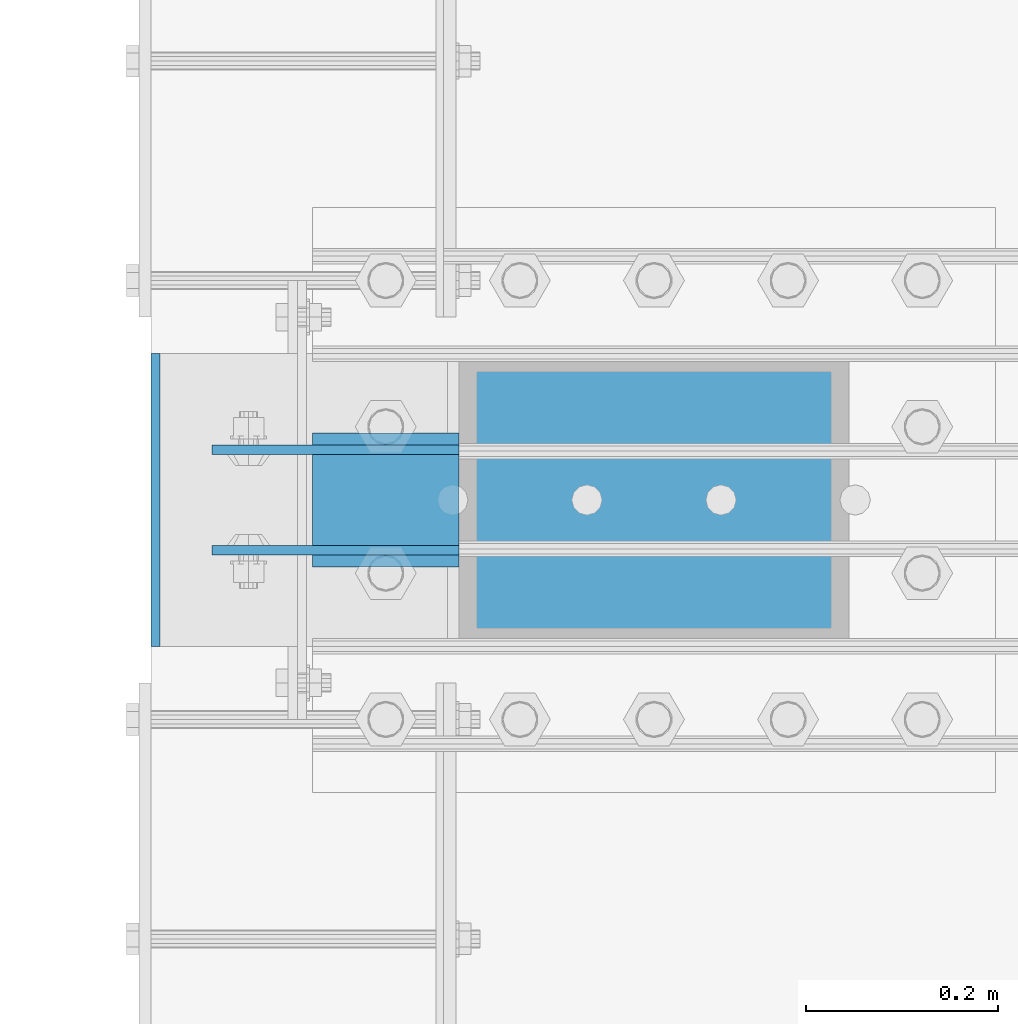
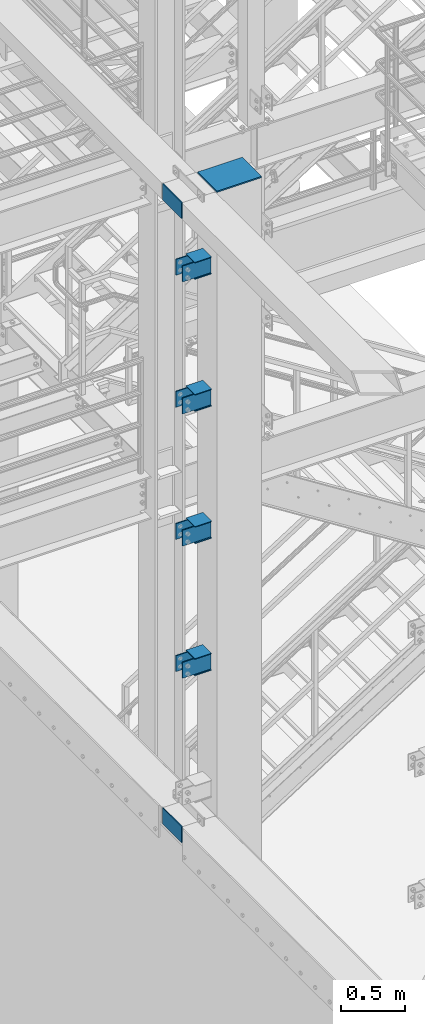
# One storey, part 1105 of 1876: 19 beams, 1 element without a shape of its own.
"""IFC2X3 building model written with IfcOpenShell, lengths in millimetres."""

from ifc_helpers import new_model, si_unit, frame, origin_with_axes, place, context, subcontext, project, spatial, faceted_brep, material, type_object, element, aggregate, save


model = new_model("IFC2X3")

# Units and contexts
model_context = context("Model", 3, precision=1e-05, world=origin_with_axes())
body_context = subcontext(model_context, "Body", "Model", "MODEL_VIEW")
ifc_project = project(units=[si_unit("LENGTHUNIT", "METRE", prefix="MILLI"), si_unit("AREAUNIT", "SQUARE_METRE"), si_unit("VOLUMEUNIT", "CUBIC_METRE"), si_unit("MASSUNIT", "GRAM", prefix="KILO"), si_unit("TIMEUNIT", "SECOND"), si_unit("PLANEANGLEUNIT", "RADIAN"), si_unit("SOLIDANGLEUNIT", "STERADIAN"), si_unit("THERMODYNAMICTEMPERATUREUNIT", "DEGREE_CELSIUS"), si_unit("LUMINOUSINTENSITYUNIT", "LUMEN")], contexts=[model_context])

# Site, building, storey
site_placement = place(None, origin_with_axes())
site = spatial("IfcSite", under=ifc_project, at=site_placement, CompositionType="ELEMENT")
building_placement = place(site_placement, origin_with_axes())
building = spatial("IfcBuilding", under=site, at=building_placement, Name="Undefined", CompositionType="ELEMENT")
storey_placement = place(building_placement, origin_with_axes())
storey = spatial("IfcBuildingStorey", under=building, at=storey_placement, Name="Undefined", CompositionType="ELEMENT", Elevation=0.0)

# Assembly, beams
assembly_placement = place(storey_placement, origin_with_axes())
assembly = element("IfcElementAssembly", 1, at=assembly_placement, inside=storey, Name="COLUMN", AssemblyPlace="NOTDEFINED", PredefinedType="RIGID_FRAME")
ifc_material = material(Name="STEEL/A36")
beam_type_1 = type_object("IfcBeamType", PredefinedType="NOTDEFINED")
beam_1_placement = place(assembly_placement, frame((434.975, -10769.6, 10661.65), z_axis=(0.0, 1.0, 0.0), x_axis=(-1.0, 0.0, 0.0)))
beam_1 = element("IfcBeam", 2, at=beam_1_placement, type_object=beam_type_1, material=ifc_material, Name="PLATE", context=body_context, shape_type="Brep", body=[
    faceted_brep([(0.0, 6.35000000000002, -152.4), (0.0, 6.35000000000002, 152.4), (406.4, 6.35000000000036, 152.4), (406.4, 6.35000000000036, -152.4), (0.0, -6.35000000000002, 152.4), (406.4, -6.35000000000036, 152.4), (0.0, -6.35000000000002, -152.4), (406.4, -6.35000000000036, -152.4)], [[[0, 1, 2, 3]], [[1, 4, 5, 2]], [[4, 6, 7, 5]], [[6, 0, 3, 7]], [[5, 7, 3, 2]], [[6, 4, 1, 0]]]),
])
beam_type_2 = type_object("IfcBeamType", PredefinedType="NOTDEFINED")
beam_2_placement = place(assembly_placement, frame((28.5750000000014, -10717.2125, 9904.4125), z_axis=(0.0, 0.0, -1.0), x_axis=(-1.0, 0.0, 0.0)))
beam_2 = element("IfcBeam", 3, at=beam_2_placement, type_object=beam_type_2, material=ifc_material, Name="PLATE", context=body_context, shape_type="Brep", body=[
    faceted_brep([(0.0, 4.76249999999982, -76.1999999999998), (3.63797880709171e-12, 4.76249999999982, 76.1999969482422), (257.174999999999, 4.76249999999982, 76.1999999999998), (257.174999999999, 4.76249999999982, -76.1999999999998), (3.63797880709171e-12, -4.76249999999982, 76.1999969482422), (257.174999999999, -4.76249999999982, 76.1999999999998), (0.0, -4.76249999999982, -76.1999999999998), (257.174999999999, -4.76249999999982, -76.1999999999998)], [[[0, 1, 2, 3]], [[1, 4, 5, 2]], [[4, 6, 7, 5]], [[6, 0, 3, 7]], [[5, 7, 3, 2]], [[6, 4, 1, 0]]]),
])
beam_3_placement = place(assembly_placement, frame((28.5750000000013, -10717.2125, 8635.47083333333), z_axis=(0.0, 0.0, -1.0), x_axis=(-1.0, 0.0, 0.0)))
beam_3 = element("IfcBeam", 4, at=beam_3_placement, type_object=beam_type_2, material=ifc_material, Name="PLATE", context=body_context, shape_type="Brep", body=[
    faceted_brep([(0.0, 4.76249999999982, -76.1999999999998), (3.63797880709171e-12, 4.76249999999982, 76.1999969482422), (257.174999999999, 4.76249999999982, 76.1999999999998), (257.174999999999, 4.76249999999982, -76.1999999999998), (3.63797880709171e-12, -4.76249999999982, 76.1999969482422), (257.174999999999, -4.76249999999982, 76.1999999999998), (0.0, -4.76249999999982, -76.1999999999998), (257.174999999999, -4.76249999999982, -76.1999999999998)], [[[0, 1, 2, 3]], [[1, 4, 5, 2]], [[4, 6, 7, 5]], [[6, 0, 3, 7]], [[5, 7, 3, 2]], [[6, 4, 1, 0]]]),
])
beam_4_placement = place(assembly_placement, frame((28.5750000000013, -10717.2125, 7366.46302033333), z_axis=(0.0, 0.0, -1.0), x_axis=(-1.0, 0.0, 0.0)))
beam_4 = element("IfcBeam", 5, at=beam_4_placement, type_object=beam_type_2, material=ifc_material, Name="PLATE", context=body_context, shape_type="Brep", body=[
    faceted_brep([(0.0, 4.76249999999982, -76.1999999999998), (3.63797880709171e-12, 4.76249999999982, 76.1999969482422), (257.174999999999, 4.76249999999982, 76.1999999999998), (257.174999999999, 4.76249999999982, -76.1999999999998), (3.63797880709171e-12, -4.76249999999982, 76.1999969482422), (257.174999999999, -4.76249999999982, 76.1999999999998), (0.0, -4.76249999999982, -76.1999999999998), (257.174999999999, -4.76249999999982, -76.1999999999998)], [[[0, 1, 2, 3]], [[1, 4, 5, 2]], [[4, 6, 7, 5]], [[6, 0, 3, 7]], [[5, 7, 3, 2]], [[6, 4, 1, 0]]]),
])
beam_5_placement = place(assembly_placement, frame((28.5750000000013, -10717.2125, 6097.5875), z_axis=(0.0, 0.0, -1.0), x_axis=(-1.0, 0.0, 0.0)))
beam_5 = element("IfcBeam", 6, at=beam_5_placement, type_object=beam_type_2, material=ifc_material, Name="PLATE", context=body_context, shape_type="Brep", body=[
    faceted_brep([(0.0, 4.76249999999982, -76.1999999999998), (3.63797880709171e-12, 4.76249999999982, 76.1999969482422), (257.174999999999, 4.76249999999982, 76.1999999999998), (257.174999999999, 4.76249999999982, -76.1999999999998), (3.63797880709171e-12, -4.76249999999982, 76.1999969482422), (257.174999999999, -4.76249999999982, 76.1999999999998), (0.0, -4.76249999999982, -76.1999999999998), (257.174999999999, -4.76249999999982, -76.1999999999998)], [[[0, 1, 2, 3]], [[1, 4, 5, 2]], [[4, 6, 7, 5]], [[6, 0, 3, 7]], [[5, 7, 3, 2]], [[6, 4, 1, 0]]]),
])
beam_6_placement = place(assembly_placement, frame((28.5750000000013, -10821.9875, 9904.4125), z_axis=(0.0, 0.0, -1.0), x_axis=(-1.0, 0.0, 0.0)))
beam_6 = element("IfcBeam", 7, at=beam_6_placement, type_object=beam_type_2, material=ifc_material, Name="PLATE", context=body_context, shape_type="Brep", body=[
    faceted_brep([(0.0, 4.76249999999982, -76.1999999999998), (3.63797880709171e-12, 4.76249999999982, 76.1999969482422), (257.174999999999, 4.76249999999982, 76.1999999999998), (257.174999999999, 4.76249999999982, -76.1999999999998), (3.63797880709171e-12, -4.76249999999982, 76.1999969482422), (257.174999999999, -4.76249999999982, 76.1999999999998), (0.0, -4.76249999999982, -76.1999999999998), (257.174999999999, -4.76249999999982, -76.1999999999998)], [[[0, 1, 2, 3]], [[1, 4, 5, 2]], [[4, 6, 7, 5]], [[6, 0, 3, 7]], [[5, 7, 3, 2]], [[6, 4, 1, 0]]]),
])
beam_7_placement = place(assembly_placement, frame((28.5750000000013, -10821.9875, 8635.47083333333), z_axis=(0.0, 0.0, -1.0), x_axis=(-1.0, 0.0, 0.0)))
beam_7 = element("IfcBeam", 8, at=beam_7_placement, type_object=beam_type_2, material=ifc_material, Name="PLATE", context=body_context, shape_type="Brep", body=[
    faceted_brep([(0.0, 4.76249999999982, -76.1999999999998), (3.63797880709171e-12, 4.76249999999982, 76.1999969482422), (257.174999999999, 4.76249999999982, 76.1999999999998), (257.174999999999, 4.76249999999982, -76.1999999999998), (3.63797880709171e-12, -4.76249999999982, 76.1999969482422), (257.174999999999, -4.76249999999982, 76.1999999999998), (0.0, -4.76249999999982, -76.1999999999998), (257.174999999999, -4.76249999999982, -76.1999999999998)], [[[0, 1, 2, 3]], [[1, 4, 5, 2]], [[4, 6, 7, 5]], [[6, 0, 3, 7]], [[5, 7, 3, 2]], [[6, 4, 1, 0]]]),
])
beam_8_placement = place(assembly_placement, frame((28.5750000000013, -10821.9875, 7366.46302033333), z_axis=(0.0, 0.0, -1.0), x_axis=(-1.0, 0.0, 0.0)))
beam_8 = element("IfcBeam", 9, at=beam_8_placement, type_object=beam_type_2, material=ifc_material, Name="PLATE", context=body_context, shape_type="Brep", body=[
    faceted_brep([(0.0, 4.76249999999982, -76.1999999999998), (3.63797880709171e-12, 4.76249999999982, 76.1999969482422), (257.174999999999, 4.76249999999982, 76.1999999999998), (257.174999999999, 4.76249999999982, -76.1999999999998), (3.63797880709171e-12, -4.76249999999982, 76.1999969482422), (257.174999999999, -4.76249999999982, 76.1999999999998), (0.0, -4.76249999999982, -76.1999999999998), (257.174999999999, -4.76249999999982, -76.1999999999998)], [[[0, 1, 2, 3]], [[1, 4, 5, 2]], [[4, 6, 7, 5]], [[6, 0, 3, 7]], [[5, 7, 3, 2]], [[6, 4, 1, 0]]]),
])
beam_9_placement = place(assembly_placement, frame((28.5750000000013, -10821.9875, 6097.5875), z_axis=(0.0, 0.0, -1.0), x_axis=(-1.0, 0.0, 0.0)))
beam_9 = element("IfcBeam", 10, at=beam_9_placement, type_object=beam_type_2, material=ifc_material, Name="PLATE", context=body_context, shape_type="Brep", body=[
    faceted_brep([(0.0, 4.76249999999982, -76.1999999999998), (3.63797880709171e-12, 4.76249999999982, 76.1999969482422), (257.174999999999, 4.76249999999982, 76.1999999999998), (257.174999999999, 4.76249999999982, -76.1999999999998), (3.63797880709171e-12, -4.76249999999982, 76.1999969482422), (257.174999999999, -4.76249999999982, 76.1999999999998), (0.0, -4.76249999999982, -76.1999999999998), (257.174999999999, -4.76249999999982, -76.1999999999998)], [[[0, 1, 2, 3]], [[1, 4, 5, 2]], [[4, 6, 7, 5]], [[6, 0, 3, 7]], [[5, 7, 3, 2]], [[6, 4, 1, 0]]]),
])
beam_10_placement = place(assembly_placement, frame((-287.337499999999, -10922.0, 4597.4), z_axis=(0.0, 0.0, 1.0), x_axis=(0.0, 1.0, 0.0)))
beam_10 = element("IfcBeam", 11, at=beam_10_placement, type_object=beam_type_2, material=ifc_material, Name="PLATE", context=body_context, shape_type="Brep", body=[
    faceted_brep([(0.0, 4.76249999999982, -76.1999999999998), (3.63797880709171e-12, 4.76249999999982, 76.1999969482422), (304.799999999999, 4.76250000000073, 76.1999999999998), (304.799999999999, 4.76250000000073, -76.1999999999998), (3.63797880709171e-12, -4.76249999999982, 76.1999969482422), (304.799999999999, -4.76250000000073, 76.1999999999998), (0.0, -4.76249999999982, -76.1999999999998), (304.799999999999, -4.76250000000073, -76.1999999999998)], [[[0, 1, 2, 3]], [[1, 4, 5, 2]], [[4, 6, 7, 5]], [[6, 0, 3, 7]], [[5, 7, 3, 2]], [[6, 4, 1, 0]]]),
])
beam_11_placement = place(assembly_placement, frame((-287.337499999999, -10922.0, 10591.8), z_axis=(0.0, 0.0, 1.0), x_axis=(0.0, 1.0, 0.0)))
beam_11 = element("IfcBeam", 12, at=beam_11_placement, type_object=beam_type_2, material=ifc_material, Name="PLATE", context=body_context, shape_type="Brep", body=[
    faceted_brep([(0.0, 4.76249999999982, -76.1999999999998), (3.63797880709171e-12, 4.76249999999982, 76.1999969482422), (304.799999999999, 4.76250000000073, 76.1999999999998), (304.799999999999, 4.76250000000073, -76.1999999999998), (3.63797880709171e-12, -4.76249999999982, 76.1999969482422), (304.799999999999, -4.76250000000073, 76.1999999999998), (0.0, -4.76249999999982, -76.1999999999998), (304.799999999999, -4.76250000000073, -76.1999999999998)], [[[0, 1, 2, 3]], [[1, 4, 5, 2]], [[4, 6, 7, 5]], [[6, 0, 3, 7]], [[5, 7, 3, 2]], [[6, 4, 1, 0]]]),
])
beam_type_3 = type_object("IfcBeamType", PredefinedType="NOTDEFINED")
beam_12_placement = place(assembly_placement, frame((28.5750000000032, -10769.6, 9825.0375), z_axis=(0.0, -1.0, 0.0), x_axis=(-1.0, 0.0, 0.0)))
beam_12 = element("IfcBeam", 13, at=beam_12_placement, type_object=beam_type_3, material=ifc_material, Name="PLATE", context=body_context, shape_type="Brep", body=[
    faceted_brep([(0.0, 3.17500000000018, -69.8499999999999), (0.0, 3.17500000000018, 69.8499999999999), (152.400000000001, 3.17500000000018, 69.8499999999999), (152.400000000001, 3.17500000000018, -69.8499999999999), (0.0, -3.17500000000018, 69.8499999999999), (152.400000000001, -3.17500000000018, 69.8499999999999), (0.0, -3.17500000000018, -69.8499999999999), (152.400000000001, -3.17500000000018, -69.8499999999999)], [[[0, 1, 2, 3]], [[1, 4, 5, 2]], [[4, 6, 7, 5]], [[6, 0, 3, 7]], [[5, 7, 3, 2]], [[6, 4, 1, 0]]]),
])
beam_13_placement = place(assembly_placement, frame((28.5749999999986, -10769.6, 9983.7875), z_axis=(0.0, -1.0, 0.0), x_axis=(-1.0, 0.0, 0.0)))
beam_13 = element("IfcBeam", 14, at=beam_13_placement, type_object=beam_type_3, material=ifc_material, Name="PLATE", context=body_context, shape_type="Brep", body=[
    faceted_brep([(0.0, 3.17500000000018, -69.8499999999999), (0.0, 3.17500000000018, 69.8499999999999), (152.400000000001, 3.17500000000018, 69.8499999999999), (152.400000000001, 3.17500000000018, -69.8499999999999), (0.0, -3.17500000000018, 69.8499999999999), (152.400000000001, -3.17500000000018, 69.8499999999999), (0.0, -3.17500000000018, -69.8499999999999), (152.400000000001, -3.17500000000018, -69.8499999999999)], [[[0, 1, 2, 3]], [[1, 4, 5, 2]], [[4, 6, 7, 5]], [[6, 0, 3, 7]], [[5, 7, 3, 2]], [[6, 4, 1, 0]]]),
])
beam_14_placement = place(assembly_placement, frame((28.5750000000032, -10769.6, 8556.09583333333), z_axis=(0.0, -1.0, 0.0), x_axis=(-1.0, 0.0, 0.0)))
beam_14 = element("IfcBeam", 15, at=beam_14_placement, type_object=beam_type_3, material=ifc_material, Name="PLATE", context=body_context, shape_type="Brep", body=[
    faceted_brep([(0.0, 3.17500000000018, -69.8499999999999), (0.0, 3.17500000000018, 69.8499999999999), (152.400000000001, 3.17500000000018, 69.8499999999999), (152.400000000001, 3.17500000000018, -69.8499999999999), (0.0, -3.17500000000018, 69.8499999999999), (152.400000000001, -3.17500000000018, 69.8499999999999), (0.0, -3.17500000000018, -69.8499999999999), (152.400000000001, -3.17500000000018, -69.8499999999999)], [[[0, 1, 2, 3]], [[1, 4, 5, 2]], [[4, 6, 7, 5]], [[6, 0, 3, 7]], [[5, 7, 3, 2]], [[6, 4, 1, 0]]]),
])
beam_15_placement = place(assembly_placement, frame((28.5749999999986, -10769.6, 8714.84583333334), z_axis=(0.0, -1.0, 0.0), x_axis=(-1.0, 0.0, 0.0)))
beam_15 = element("IfcBeam", 16, at=beam_15_placement, type_object=beam_type_3, material=ifc_material, Name="PLATE", context=body_context, shape_type="Brep", body=[
    faceted_brep([(0.0, 3.17500000000018, -69.8499999999999), (0.0, 3.17500000000018, 69.8499999999999), (152.400000000001, 3.17500000000018, 69.8499999999999), (152.400000000001, 3.17500000000018, -69.8499999999999), (0.0, -3.17500000000018, 69.8499999999999), (152.400000000001, -3.17500000000018, 69.8499999999999), (0.0, -3.17500000000018, -69.8499999999999), (152.400000000001, -3.17500000000018, -69.8499999999999)], [[[0, 1, 2, 3]], [[1, 4, 5, 2]], [[4, 6, 7, 5]], [[6, 0, 3, 7]], [[5, 7, 3, 2]], [[6, 4, 1, 0]]]),
])
beam_16_placement = place(assembly_placement, frame((28.5750000000032, -10769.6, 7287.08802033333), z_axis=(0.0, -1.0, 0.0), x_axis=(-1.0, 0.0, 0.0)))
beam_16 = element("IfcBeam", 17, at=beam_16_placement, type_object=beam_type_3, material=ifc_material, Name="PLATE", context=body_context, shape_type="Brep", body=[
    faceted_brep([(0.0, 3.17500000000018, -69.8499999999999), (0.0, 3.17500000000018, 69.8499999999999), (152.400000000001, 3.17500000000018, 69.8499999999999), (152.400000000001, 3.17500000000018, -69.8499999999999), (0.0, -3.17500000000018, 69.8499999999999), (152.400000000001, -3.17500000000018, 69.8499999999999), (0.0, -3.17500000000018, -69.8499999999999), (152.400000000001, -3.17500000000018, -69.8499999999999)], [[[0, 1, 2, 3]], [[1, 4, 5, 2]], [[4, 6, 7, 5]], [[6, 0, 3, 7]], [[5, 7, 3, 2]], [[6, 4, 1, 0]]]),
])
beam_17_placement = place(assembly_placement, frame((28.5749999999986, -10769.6, 7445.83802033334), z_axis=(0.0, -1.0, 0.0), x_axis=(-1.0, 0.0, 0.0)))
beam_17 = element("IfcBeam", 18, at=beam_17_placement, type_object=beam_type_3, material=ifc_material, Name="PLATE", context=body_context, shape_type="Brep", body=[
    faceted_brep([(0.0, 3.17500000000018, -69.8499999999999), (0.0, 3.17500000000018, 69.8499999999999), (152.400000000001, 3.17500000000018, 69.8499999999999), (152.400000000001, 3.17500000000018, -69.8499999999999), (0.0, -3.17500000000018, 69.8499999999999), (152.400000000001, -3.17500000000018, 69.8499999999999), (0.0, -3.17500000000018, -69.8499999999999), (152.400000000001, -3.17500000000018, -69.8499999999999)], [[[0, 1, 2, 3]], [[1, 4, 5, 2]], [[4, 6, 7, 5]], [[6, 0, 3, 7]], [[5, 7, 3, 2]], [[6, 4, 1, 0]]]),
])
beam_18_placement = place(assembly_placement, frame((28.5750000000032, -10769.6, 6018.2125), z_axis=(0.0, -1.0, 0.0), x_axis=(-1.0, 0.0, 0.0)))
beam_18 = element("IfcBeam", 19, at=beam_18_placement, type_object=beam_type_3, material=ifc_material, Name="PLATE", context=body_context, shape_type="Brep", body=[
    faceted_brep([(0.0, 3.17500000000018, -69.8499999999999), (0.0, 3.17500000000018, 69.8499999999999), (152.400000000001, 3.17500000000018, 69.8499999999999), (152.400000000001, 3.17500000000018, -69.8499999999999), (0.0, -3.17500000000018, 69.8499999999999), (152.400000000001, -3.17500000000018, 69.8499999999999), (0.0, -3.17500000000018, -69.8499999999999), (152.400000000001, -3.17500000000018, -69.8499999999999)], [[[0, 1, 2, 3]], [[1, 4, 5, 2]], [[4, 6, 7, 5]], [[6, 0, 3, 7]], [[5, 7, 3, 2]], [[6, 4, 1, 0]]]),
])
beam_19_placement = place(assembly_placement, frame((28.5749999999986, -10769.6, 6176.9625), z_axis=(0.0, -1.0, 0.0), x_axis=(-1.0, 0.0, 0.0)))
beam_19 = element("IfcBeam", 20, at=beam_19_placement, type_object=beam_type_3, material=ifc_material, Name="PLATE", context=body_context, shape_type="Brep", body=[
    faceted_brep([(0.0, 3.17500000000018, -69.8499999999999), (0.0, 3.17500000000018, 69.8499999999999), (152.400000000001, 3.17500000000018, 69.8499999999999), (152.400000000001, 3.17500000000018, -69.8499999999999), (0.0, -3.17500000000018, 69.8499999999999), (152.400000000001, -3.17500000000018, 69.8499999999999), (0.0, -3.17500000000018, -69.8499999999999), (152.400000000001, -3.17500000000018, -69.8499999999999)], [[[0, 1, 2, 3]], [[1, 4, 5, 2]], [[4, 6, 7, 5]], [[6, 0, 3, 7]], [[5, 7, 3, 2]], [[6, 4, 1, 0]]]),
])
aggregate(assembly, [beam_12, beam_13, beam_14, beam_15, beam_16, beam_17, beam_18, beam_19, beam_2, beam_3, beam_4, beam_5, beam_6, beam_7, beam_8, beam_9, beam_1, beam_10, beam_11])

save(model, "model.ifc")
